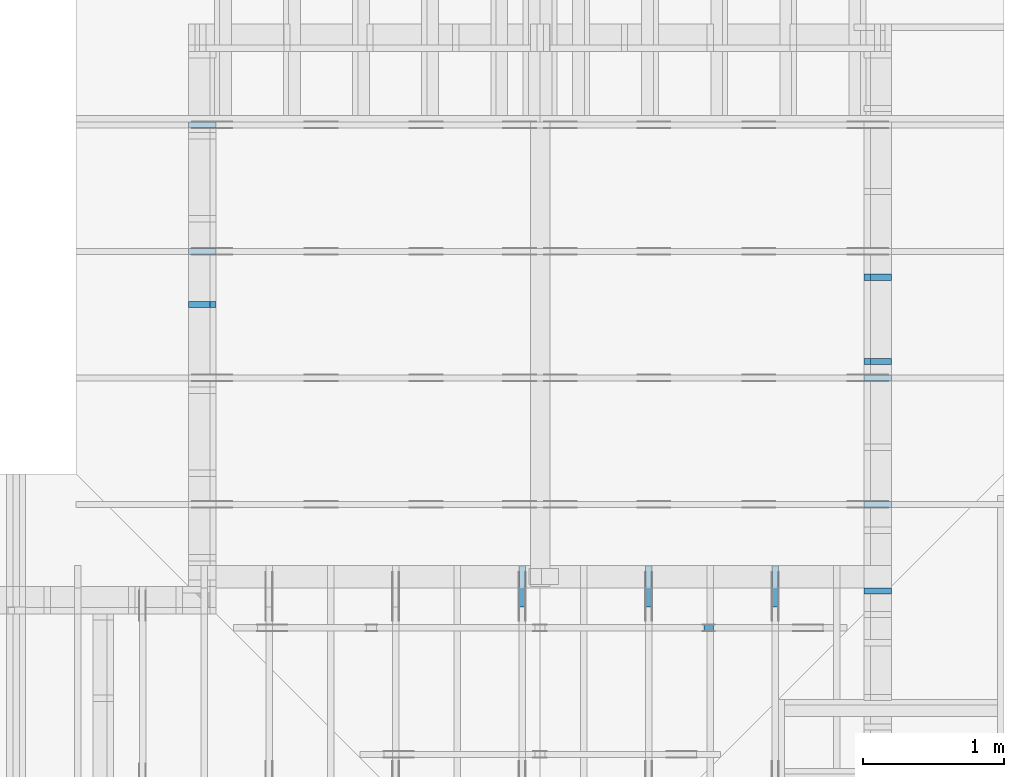
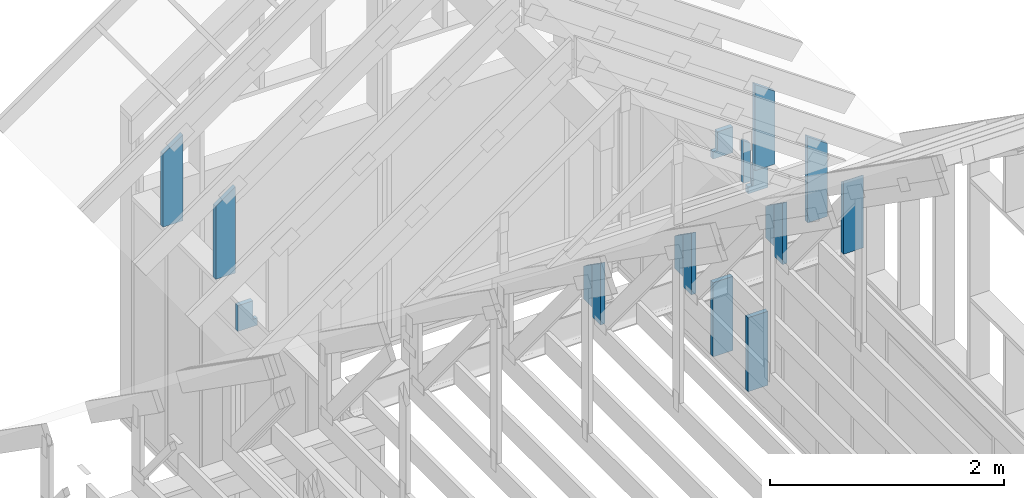
# One storey, part 42 of 70: 17 members, 11 elements without a shape of their own.
"""IFC2X3 building model written with IfcOpenShell, lengths in millimetres."""

from ifc_helpers import new_model, si_unit, frame, origin, origin_with_axes, origin_2d, place, context, project, spatial, faceted_brep, element, aggregate, save


model = new_model("IFC2X3")

# Units and contexts
model_context = context("Model", 3, precision=1e-05, world=origin())
plan_context = context("Plan", 2, precision=1e-05, world=origin_2d())
ifc_project = project(units=[si_unit("LENGTHUNIT", "METRE", prefix="MILLI"), si_unit("AREAUNIT", "SQUARE_METRE"), si_unit("VOLUMEUNIT", "CUBIC_METRE"), si_unit("SOLIDANGLEUNIT", "STERADIAN"), si_unit("PLANEANGLEUNIT", "RADIAN"), si_unit("MASSUNIT", "GRAM"), si_unit("TIMEUNIT", "SECOND"), si_unit("THERMODYNAMICTEMPERATUREUNIT", "DEGREE_CELSIUS"), si_unit("LUMINOUSINTENSITYUNIT", "LUMEN")], contexts=[model_context, plan_context])

# Site, building, storey
site_placement = place(None, origin_with_axes())
site = spatial("IfcSite", under=ifc_project, at=site_placement, CompositionType="ELEMENT")
building_placement = place(site_placement, origin_with_axes())
building = spatial("IfcBuilding", under=site, at=building_placement, Name="Layout 1", CompositionType="ELEMENT")
storey_placement = place(building_placement, origin_with_axes())
storey = spatial("IfcBuildingStorey", under=building, at=storey_placement, Name="Storey 1", CompositionType="ELEMENT", Elevation=0.0)

# Assembly, member
assembly_1_placement = place(storey_placement, frame((7000.0, 11305.0, 1.3776821480501744e-15), z_axis=(1.2246063538223773e-16, 1.0, 6.123031769111886e-17), x_axis=(-1.0, 1.2246063538223773e-16, 0.0)))
assembly_1 = element("IfcElementAssembly", 1, at=assembly_1_placement, inside=storey, Name="T4", AssemblyPlace="FACTORY", PredefinedType="TRUSS")
member_1_placement = place(assembly_1_placement, frame((-195.00000000029104, 898.4894251432052, -45.0), z_axis=(0.0, 0.0, 1.0), x_axis=(-1.960047792473607e-15, -1.0, 0.0)))
member_1 = element("IfcMember", 2, at=member_1_placement, Name="E2", context=model_context, shape_type="Brep", body=[
    faceted_brep([(898.4894251432048, 195.0000000002928, 45.0), (136.54046995116335, 195.0000000002928, 45.0), (0.0, 0.0, 45.0), (898.4894251432048, 0.0, 45.0), (136.54046995116335, 195.0000000002928, 1.67208327056088e-14), (898.4894251432048, 195.0000000002928, 1.1002958588725838e-13), (898.4894251432048, 0.0, 1.1002958588725838e-13), (0.0, 0.0, 0.0), (-1.1640850691049727e-14, 8.15101140505067e-15, 8.701351488741532e-31), (-9.383788395138588e-15, 6.5705993712440116e-15, 45.0), (136.54046995116337, 195.00000000029124, 45.0), (136.54046995116337, 195.00000000029124, -3.074169377230906e-30), (898.4894251432048, 2.9190987951436253e-10, 5.452994756240366e-29), (898.4894251432048, 2.9191263487865863e-10, 45.0), (-8.951892333787164e-28, 2.755364296100349e-15, 45.0), (0.0, 0.0, 0.0), (898.4894251432048, 195.0000000002928, 0.0), (898.4894251432048, 195.0000000002928, 45.0), (898.4894251432048, 2.928004505520221e-10, 45.0), (898.4894251432048, 2.928004505520221e-10, 0.0), (136.54046995116332, 195.0000000002913, 0.0), (136.54046995116332, 195.0000000002913, 45.0), (898.4894251432048, 195.00000000029277, 45.0), (898.4894251432048, 195.00000000029277, 0.0)], [[[0, 1, 2, 3]], [[4, 5, 6, 7]], [[8, 9, 10, 11]], [[12, 13, 14, 15]], [[16, 17, 18, 19]], [[20, 21, 22, 23]]]),
])
aggregate(assembly_1, [member_1])

assembly_2_placement = place(storey_placement, frame((7000.0, 10405.0, 1.3776821480501744e-15), z_axis=(1.2246063538223773e-16, 1.0, 6.123031769111886e-17), x_axis=(-1.0, 1.2246063538223773e-16, 0.0)))
assembly_2 = element("IfcElementAssembly", 3, at=assembly_2_placement, inside=storey, Name="T4", AssemblyPlace="FACTORY", PredefinedType="TRUSS")
member_2_placement = place(assembly_2_placement, frame((-195.00000000029104, 898.4894251432052, -45.0), z_axis=(0.0, 0.0, 1.0), x_axis=(-1.960047792473607e-15, -1.0, 0.0)))
member_2 = element("IfcMember", 4, at=member_2_placement, Name="E2", context=model_context, shape_type="Brep", body=[
    faceted_brep([(898.4894251432048, 195.0000000002928, 45.0), (136.54046995116335, 195.0000000002928, 45.0), (0.0, 0.0, 45.0), (898.4894251432048, 0.0, 45.0), (136.54046995116335, 195.0000000002928, 1.67208327056088e-14), (898.4894251432048, 195.0000000002928, 1.1002958588725838e-13), (898.4894251432048, 0.0, 1.1002958588725838e-13), (0.0, 0.0, 0.0), (-1.1640850691049727e-14, 8.15101140505067e-15, 8.701351488741532e-31), (-9.383788395138588e-15, 6.5705993712440116e-15, 45.0), (136.54046995116337, 195.00000000029124, 45.0), (136.54046995116337, 195.00000000029124, -3.074169377230906e-30), (898.4894251432048, 2.9190987951436253e-10, 5.452994756240366e-29), (898.4894251432048, 2.9191263487865863e-10, 45.0), (-8.951892333787164e-28, 2.755364296100349e-15, 45.0), (0.0, 0.0, 0.0), (898.4894251432048, 195.0000000002928, 0.0), (898.4894251432048, 195.0000000002928, 45.0), (898.4894251432048, 2.928004505520221e-10, 45.0), (898.4894251432048, 2.928004505520221e-10, 0.0), (136.54046995116332, 195.0000000002913, 0.0), (136.54046995116332, 195.0000000002913, 45.0), (898.4894251432048, 195.00000000029277, 45.0), (898.4894251432048, 195.00000000029277, 0.0)], [[[0, 1, 2, 3]], [[4, 5, 6, 7]], [[8, 9, 10, 11]], [[12, 13, 14, 15]], [[16, 17, 18, 19]], [[20, 21, 22, 23]]]),
])
aggregate(assembly_2, [member_2])

assembly_3_placement = place(storey_placement, frame((7000.0, 11805.0, -2470.0), z_axis=(-1.0, 1.836909530733566e-16, 6.123031769111886e-17), x_axis=(-1.836909530733566e-16, -1.0, 0.0)))
assembly_3 = element("IfcElementAssembly", 5, at=assembly_3_placement, inside=storey, Name="VE1", AssemblyPlace="FACTORY", PredefinedType="NOTDEFINED")
member_3_placement = place(assembly_3_placement, frame((1777.5000000036816, 2425.0, -195.00000000000003), z_axis=(0.0, 0.0, 1.0), x_axis=(-1.836909530733566e-16, -1.0, 0.0)))
member_3 = element("IfcMember", 6, at=member_3_placement, Name="S40", context=model_context, shape_type="Brep", body=[
    faceted_brep([(0.0, 45.00000000001455, 45.00000000000003), (195.00000000186265, 45.00000000001455, 45.00000000000005), (195.00000000186265, 0.0, 45.00000000000005), (0.0, 0.0, 45.00000000000003), (195.00000000186265, 45.00000000001455, 2.842170943040401e-14), (195.00000000186265, 45.00000000001455, 45.00000000000003), (195.00000000186265, 1.0459189070388675e-11, 45.00000000000003), (195.00000000186265, 1.0459189070388675e-11, 2.842170943040401e-14), (2.7553642961003504e-15, -3.3742366240998114e-31, 45.00000000000003), (1.1939911949768181e-14, -1.4621692037765844e-30, 195.00000000000006), (1.7450640541970662e-14, 45.00000000001455, 195.00000000000006), (8.26609288830283e-15, 45.00000000001455, 45.00000000000003), (270.0, -4.959655732980628e-14, 2.842170943040401e-14), (270.0, -3.76566453800381e-14, 195.00000000000003), (2.1932538056648764e-30, 1.193991194976818e-14, 195.00000000000003), (5.061354936149717e-31, 2.7553642961003504e-15, 45.00000000000003), (195.00000000186265, -3.306437155354634e-14, 45.00000000000003), (195.00000000186265, -3.5819735849646686e-14, 2.842170943040401e-14), (-1.6871183120499057e-31, 45.00000000001455, 45.00000000000003), (-7.310846018882921e-31, 45.00000000001454, 195.00000000000003), (270.0, 45.00000000001452, 195.00000000000003), (270.0, 45.00000000001454, 2.8421709430404004e-14), (195.00000000186265, 45.00000000001454, 2.8421709430404004e-14), (195.00000000186265, 45.00000000001454, 45.00000000000003), (270.0, 45.00000000001455, 0.0), (270.0, 45.00000000001455, 195.00000000000003), (270.0, 1.4551915228366852e-11, 195.00000000000003), (270.0, 1.4551915228366852e-11, 0.0), (270.0, 45.00000000001455, 195.00000000000003), (0.0, 45.00000000001455, 195.00000000000003), (0.0, 0.0, 195.00000000000003), (270.0, 0.0, 195.00000000000003), (195.00000000186265, 45.00000000001455, 5.2301533330168465e-14), (270.0, 45.00000000001455, 6.148608098360819e-14), (270.0, 1.4551915228366852e-11, 6.148608098360819e-14), (195.00000000186265, 1.4551915228366852e-11, 5.2301533330168465e-14)], [[[0, 1, 2, 3]], [[4, 5, 6, 7]], [[8, 9, 10, 11]], [[12, 13, 14, 15, 16, 17]], [[18, 19, 20, 21, 22, 23]], [[24, 25, 26, 27]], [[28, 29, 30, 31]], [[32, 33, 34, 35]]]),
])
aggregate(assembly_3, [member_3])

# Assembly, members
assembly_4_placement = place(storey_placement, frame((12000.0, 0.0, -2470.0), z_axis=(1.0, -6.123031769111886e-17, 6.123031769111886e-17), x_axis=(6.123031769111886e-17, 1.0, 0.0)))
assembly_4 = element("IfcElementAssembly", 7, at=assembly_4_placement, inside=storey, Name="VE5", AssemblyPlace="FACTORY", PredefinedType="NOTDEFINED")
member_4_placement = place(assembly_4_placement, frame((9577.500000001834, 2425.0, -195.00000000000003), z_axis=(0.0, 0.0, 1.0), x_axis=(-1.836909530733566e-16, -1.0, 0.0)))
member_4 = element("IfcMember", 8, at=member_4_placement, Name="S40", context=model_context, shape_type="Brep", body=[
    faceted_brep([(0.0, 45.0, 45.00000000000003), (195.00000000186265, 45.0, 45.00000000000005), (195.00000000186265, 0.0, 45.00000000000005), (0.0, 0.0, 45.00000000000003), (195.00000000186265, 45.000000000010914, 2.842170943040401e-14), (195.00000000186265, 45.000000000010914, 45.00000000000003), (195.00000000186265, 1.0913936421275139e-11, 45.00000000000003), (195.00000000186265, 1.0913936421275139e-11, 2.842170943040401e-14), (2.7553642961003504e-15, -3.3742366240998114e-31, 45.00000000000003), (1.193991194976818e-14, -1.4621692037765842e-30, 195.00000000000003), (1.7450640541968876e-14, 45.0, 195.00000000000003), (8.266092888301048e-15, 45.0, 45.00000000000003), (270.0, -4.959655732980628e-14, 2.842170943040401e-14), (270.0, -3.76566453800381e-14, 195.00000000000003), (2.1932538056648764e-30, 1.193991194976818e-14, 195.00000000000003), (5.061354936149717e-31, 2.7553642961003504e-15, 45.00000000000003), (195.00000000186265, -3.306437155354634e-14, 45.00000000000003), (195.00000000186265, -3.5819735849646686e-14, 2.842170943040401e-14), (-1.6871183120499057e-31, 45.000000000010914, 45.00000000000003), (-7.310846018882921e-31, 45.0000000000109, 195.00000000000003), (270.0, 45.000000000010886, 195.00000000000003), (270.0, 45.0000000000109, 2.842170943040401e-14), (195.00000000186265, 45.0000000000109, 2.842170943040401e-14), (195.00000000186265, 45.0000000000109, 45.00000000000003), (270.0, 45.00000000001455, 0.0), (270.0, 45.00000000001455, 195.00000000000003), (270.0, 1.4551915228366852e-11, 195.00000000000003), (270.0, 1.4551915228366852e-11, 0.0), (270.0, 45.00000000001455, 195.00000000000003), (0.0, 45.00000000001455, 195.00000000000003), (0.0, 0.0, 195.00000000000003), (270.0, 0.0, 195.00000000000003), (195.00000000186265, 45.000000000010914, 5.2301533330168465e-14), (270.0, 45.000000000010914, 6.148608098360819e-14), (270.0, 1.4551915228366852e-11, 6.148608098360819e-14), (195.00000000186265, 1.4551915228366852e-11, 5.2301533330168465e-14)], [[[0, 1, 2, 3]], [[4, 5, 6, 7]], [[8, 9, 10, 11]], [[12, 13, 14, 15, 16, 17]], [[18, 19, 20, 21, 22, 23]], [[24, 25, 26, 27]], [[28, 29, 30, 31]], [[32, 33, 34, 35]]]),
])
member_5_placement = place(assembly_4_placement, frame((9577.500000001819, 863.171384747213, -195.0), z_axis=(0.0, 0.0, 1.0), x_axis=(-1.836909530733566e-16, -1.0, 0.0)))
member_5 = element("IfcMember", 9, at=member_5_placement, Name="S36", context=model_context, shape_type="Brep", body=[
    faceted_brep([(773.1713847472129, 45.0, 195.0), (0.0, 45.0, 195.0), (1.1368683772161603e-13, 2.9103830456733704e-11, 195.0), (773.1713847472129, 2.9103830456733704e-11, 195.0), (0.0, 45.0, 0.0), (773.1713847472129, 45.0, 9.468305903550827e-14), (773.1713847472129, 2.9103830456733704e-11, 9.468305903550827e-14), (1.1368683772161603e-13, 2.9103830456733704e-11, 1.392216238198645e-29), (1.1368683772161555e-13, 2.9103830456733704e-11, 2.942726775082116e-44), (1.2562674967138373e-13, 2.9103830456733704e-11, 195.0), (1.123339160406752e-14, 45.000000000029104, 195.0), (-7.065203457006586e-16, 45.000000000029104, 4.326046522249051e-32), (773.1713847472129, 1.1981204437069186e-13, -7.336129540039744e-30), (773.1713847472129, 1.3175195632046003e-13, 195.0), (1.1368683772161646e-13, 2.911577036868347e-11, 195.0), (1.1368683772161603e-13, 2.9103830456733704e-11, 0.0), (773.1713847472129, 45.0, 0.0), (773.1713847472129, 45.0, 195.0), (773.1713847472129, 0.0, 195.0), (773.1713847472129, 0.0, 0.0), (0.0, 45.000000000029104, 0.0), (-4.0389678347315804e-28, 45.00000000002909, 195.0), (773.1713847472129, 45.00000000000003, 195.0), (773.1713847472129, 45.00000000000004, 2.7610131682735413e-30)], [[[0, 1, 2, 3]], [[4, 5, 6, 7]], [[8, 9, 10, 11]], [[12, 13, 14, 15]], [[16, 17, 18, 19]], [[20, 21, 22, 23]]]),
])
member_6_placement = place(assembly_4_placement, frame((10177.500000001834, 2425.0, -195.0), z_axis=(0.0, 0.0, 1.0), x_axis=(-1.836909530733566e-16, -1.0, 0.0)))
member_6 = element("IfcMember", 10, at=member_6_placement, Name="S40", context=model_context, shape_type="Brep", body=[
    faceted_brep([(0.0, 45.0, 45.0), (195.00000000186265, 45.0, 45.00000000000002), (195.00000000186265, 0.0, 45.00000000000002), (0.0, 0.0, 45.0), (195.00000000186265, 45.000000000010914, 0.0), (195.00000000186265, 45.000000000010914, 45.0), (195.00000000186265, 0.0, 45.0), (195.00000000186265, 0.0, 0.0), (2.755364296100349e-15, -3.3742366240998092e-31, 45.0), (1.1939911949768178e-14, -1.462169203776584e-30, 195.0), (1.7450640541968876e-14, 45.0, 195.0), (8.266092888301046e-15, 45.0, 45.0), (270.0, -4.959655732980628e-14, 3.0368129616898283e-30), (270.0, -3.76566453800381e-14, 195.0), (2.193253805664876e-30, 1.1939911949768178e-14, 195.0), (5.061354936149714e-31, 2.755364296100349e-15, 45.0), (195.00000000186265, -3.306437155354634e-14, 45.0), (195.00000000186265, -3.5819735849646686e-14, 2.193253805685826e-30), (-1.6871183120499046e-31, 45.000000000010914, 45.0), (-7.31084601888292e-31, 45.0000000000109, 195.0), (270.0, 45.000000000010886, 195.0), (270.0, 45.0000000000109, -1.1832913578315177e-30), (195.00000000186265, 45.0000000000109, -7.888609052210118e-31), (195.00000000186265, 45.0000000000109, 45.0), (270.0, 45.00000000001455, 0.0), (270.0, 45.00000000001455, 195.0), (270.0, 0.0, 195.0), (270.0, 0.0, 0.0), (270.0, 45.00000000001455, 195.0), (0.0, 45.00000000001455, 195.0), (0.0, 0.0, 195.0), (270.0, 0.0, 195.0), (195.00000000186265, 45.000000000010914, 2.3879823899764457e-14), (270.0, 45.000000000010914, 3.3064371553204186e-14), (270.0, 0.0, 3.3064371553204186e-14), (195.00000000186265, 0.0, 2.3879823899764457e-14)], [[[0, 1, 2, 3]], [[4, 5, 6, 7]], [[8, 9, 10, 11]], [[12, 13, 14, 15, 16, 17]], [[18, 19, 20, 21, 22, 23]], [[24, 25, 26, 27]], [[28, 29, 30, 31]], [[32, 33, 34, 35]]]),
])
member_7_placement = place(assembly_4_placement, frame((10177.500000001819, 863.171384747213, -195.0), z_axis=(0.0, 0.0, 1.0), x_axis=(-1.836909530733566e-16, -1.0, 0.0)))
member_7 = element("IfcMember", 11, at=member_7_placement, Name="S36", context=model_context, shape_type="Brep", body=[
    faceted_brep([(773.1713847472129, 45.0, 195.0), (0.0, 45.0, 195.0), (1.1368683772161603e-13, 1.4551915228366852e-11, 195.0), (773.1713847472129, 1.4551915228366852e-11, 195.0), (0.0, 45.0, 0.0), (773.1713847472129, 45.0, 9.468305903550827e-14), (773.1713847472129, 1.4551915228366852e-11, 9.468305903550827e-14), (1.1368683772161603e-13, 1.4551915228366852e-11, 1.392216238198645e-29), (1.1368683772161582e-13, 1.4551915228366852e-11, 1.2611686178923354e-44), (1.25626749671384e-13, 1.4551915228366852e-11, 195.0), (1.123339160403079e-14, 45.000000000029104, 195.0), (-7.06520345737388e-16, 45.000000000029104, 4.3260465224739594e-32), (773.1713847472129, -1.1106272091285424e-14, 6.800405685133444e-31), (773.1713847472129, 8.336398584827545e-16, 195.0), (1.1368683772161626e-13, 1.456385514031662e-11, 195.0), (1.1368683772161603e-13, 1.4551915228366852e-11, 0.0), (773.1713847472129, 45.0, 0.0), (773.1713847472129, 45.0, 195.0), (773.1713847472129, 0.0, 195.0), (773.1713847472129, 0.0, 0.0), (0.0, 45.000000000029104, 0.0), (-4.0389678347315804e-28, 45.00000000002909, 195.0), (773.1713847472129, 45.00000000000003, 195.0), (773.1713847472129, 45.00000000000004, 2.7610131682735413e-30)], [[[0, 1, 2, 3]], [[4, 5, 6, 7]], [[8, 9, 10, 11]], [[12, 13, 14, 15]], [[16, 17, 18, 19]], [[20, 21, 22, 23]]]),
])
aggregate(assembly_4, [member_4, member_5, member_6, member_7])

assembly_5_placement = place(storey_placement, frame((10250.0, 8000.0, -9.081170196248781e-13), z_axis=(-1.0, 1.836909530733566e-16, 6.123031769111886e-17), x_axis=(-1.836909530733566e-16, -1.0, 0.0)))
assembly_5 = element("IfcElementAssembly", 12, at=assembly_5_placement, inside=storey, Name="T3", AssemblyPlace="FACTORY", PredefinedType="TRUSS")
member_8_placement = place(assembly_5_placement, frame((145.0000000001018, 220.00000000000097, -45.0), z_axis=(0.0, 0.0, 1.0), x_axis=(6.123031769111886e-17, 1.0, 0.0)))
member_8 = element("IfcMember", 13, at=member_8_placement, Name="E3", context=model_context, shape_type="Brep", body=[
    faceted_brep([(541.9489551912693, 145.00000000010186, 45.0), (0.0, 145.00000000010186, 45.0), (0.0, 1.964451712410664e-09, 45.0), (643.4790482318776, 1.964451712410664e-09, 45.0), (0.0, 145.00000000010186, 0.0), (541.9489551912693, 145.00000000010186, 6.636741339746272e-14), (643.4790482318776, 1.964451712410664e-09, 7.880085310163334e-14), (0.0, 1.964451712410664e-09, 0.0), (2.4056800487953487e-25, 1.964451712410664e-09, -1.4730055365092553e-41), (2.7553642963409167e-15, 1.964451712410664e-09, 45.0), (2.0512156426537286e-14, 145.0000000001018, 45.0), (1.7756792130436937e-14, 145.0000000001018, -1.087254023321813e-30), (643.4790482318776, 4.8214030877080846e-15, -2.952160427766236e-31), (643.4790482318776, 7.576767383808433e-15, 45.0), (8.411721935180507e-27, 1.9644544677749603e-09, 45.0), (0.0, 1.964451712410664e-09, 0.0), (541.9489551912693, 145.00000000010183, -6.310887241768095e-30), (541.9489551912693, 145.00000000010183, 45.0), (643.4790482318776, 0.0, 45.0), (643.4790482318776, 0.0, -6.310887241768095e-30), (0.0, 145.0000000001018, 0.0), (0.0, 145.0000000001018, 45.0), (541.9489551912693, 145.0000000001019, 45.0), (541.9489551912693, 145.0000000001019, 1.5777218104420236e-30)], [[[0, 1, 2, 3]], [[4, 5, 6, 7]], [[8, 9, 10, 11]], [[12, 13, 14, 15]], [[16, 17, 18, 19]], [[20, 21, 22, 23]]]),
])
member_9_placement = place(assembly_5_placement, frame((0.0, 322.49999999813735, -45.0), z_axis=(0.0, 0.0, 1.0), x_axis=(6.123031769111886e-17, 1.0, 0.0)))
member_9 = element("IfcMember", 14, at=member_9_placement, Name="E4", context=model_context, shape_type="Brep", body=[
    faceted_brep([(337.91886215284467, 145.0, 45.0), (0.0, 145.0, 45.0), (0.0, 0.0, 45.0), (439.44895519316196, 0.0, 45.0), (0.0, 145.0, 0.0), (337.91886215284467, 145.0, 4.138175856688016e-14), (439.44895519316196, 0.0, 5.381519827101513e-14), (0.0, 0.0, 0.0), (0.0, 0.0, 0.0), (2.755364296100349e-15, -3.3742366240998092e-31, 45.0), (2.051215642652482e-14, 145.0, 45.0), (1.775679213042447e-14, 145.0, -1.0872540233210496e-30), (439.44895519316196, -8.07227974065227e-14, 6.590243373489615e-30), (439.44895519316196, -7.796743311042235e-14, 45.0), (5.061354936149714e-31, 2.755364296100349e-15, 45.0), (0.0, 0.0, 0.0), (337.91886215284467, 144.99999999999997, 0.0), (337.91886215284467, 144.99999999999997, 45.0), (439.44895519316196, 0.0, 45.0), (439.44895519316196, 0.0, 0.0), (0.0, 145.0, 0.0), (-1.6871183120499046e-31, 145.0, 45.0), (337.91886215284467, 144.99999999999997, 45.0), (337.91886215284467, 144.99999999999997, -1.5777218104420236e-30)], [[[0, 1, 2, 3]], [[4, 5, 6, 7]], [[8, 9, 10, 11]], [[12, 13, 14, 15]], [[16, 17, 18, 19]], [[20, 21, 22, 23]]]),
])
aggregate(assembly_5, [member_8, member_9])

assembly_6_placement = place(storey_placement, frame((9350.0, 8000.0, -9.081170196248781e-13), z_axis=(-1.0, 1.836909530733566e-16, 6.123031769111886e-17), x_axis=(-1.836909530733566e-16, -1.0, 0.0)))
assembly_6 = element("IfcElementAssembly", 15, at=assembly_6_placement, inside=storey, Name="T3", AssemblyPlace="FACTORY", PredefinedType="TRUSS")
member_10_placement = place(assembly_6_placement, frame((145.0000000001018, 220.00000000000097, -45.0), z_axis=(0.0, 0.0, 1.0), x_axis=(6.123031769111886e-17, 1.0, 0.0)))
member_10 = element("IfcMember", 16, at=member_10_placement, Name="E3", context=model_context, shape_type="Brep", body=[
    faceted_brep([(541.9489551912693, 145.00000000010186, 45.0), (0.0, 145.00000000010186, 45.0), (0.0, 1.964451712410664e-09, 45.0), (643.4790482318776, 1.964451712410664e-09, 45.0), (0.0, 145.00000000010186, 0.0), (541.9489551912693, 145.00000000010186, 6.636741339746272e-14), (643.4790482318776, 1.964451712410664e-09, 7.880085310163334e-14), (0.0, 1.964451712410664e-09, 0.0), (2.4056800487953487e-25, 1.964451712410664e-09, -1.4730055365092553e-41), (2.7553642963409167e-15, 1.964451712410664e-09, 45.0), (2.0512156426537286e-14, 145.0000000001018, 45.0), (1.7756792130436937e-14, 145.0000000001018, -1.087254023321813e-30), (643.4790482318776, 4.8214030877080846e-15, -2.952160427766236e-31), (643.4790482318776, 7.576767383808433e-15, 45.0), (8.411721935180507e-27, 1.9644544677749603e-09, 45.0), (0.0, 1.964451712410664e-09, 0.0), (541.9489551912693, 145.00000000010183, -6.310887241768095e-30), (541.9489551912693, 145.00000000010183, 45.0), (643.4790482318776, 0.0, 45.0), (643.4790482318776, 0.0, -6.310887241768095e-30), (0.0, 145.0000000001018, 0.0), (0.0, 145.0000000001018, 45.0), (541.9489551912693, 145.0000000001019, 45.0), (541.9489551912693, 145.0000000001019, 1.5777218104420236e-30)], [[[0, 1, 2, 3]], [[4, 5, 6, 7]], [[8, 9, 10, 11]], [[12, 13, 14, 15]], [[16, 17, 18, 19]], [[20, 21, 22, 23]]]),
])
member_11_placement = place(assembly_6_placement, frame((0.0, 322.49999999813735, -45.0), z_axis=(0.0, 0.0, 1.0), x_axis=(6.123031769111886e-17, 1.0, 0.0)))
member_11 = element("IfcMember", 17, at=member_11_placement, Name="E4", context=model_context, shape_type="Brep", body=[
    faceted_brep([(337.91886215284467, 145.0, 45.0), (0.0, 145.0, 45.0), (0.0, 0.0, 45.0), (439.44895519316196, 0.0, 45.0), (0.0, 145.0, 0.0), (337.91886215284467, 145.0, 4.138175856688016e-14), (439.44895519316196, 0.0, 5.381519827101513e-14), (0.0, 0.0, 0.0), (0.0, 0.0, 0.0), (2.755364296100349e-15, -3.3742366240998092e-31, 45.0), (2.051215642652482e-14, 145.0, 45.0), (1.775679213042447e-14, 145.0, -1.0872540233210496e-30), (439.44895519316196, -8.07227974065227e-14, 6.590243373489615e-30), (439.44895519316196, -7.796743311042235e-14, 45.0), (5.061354936149714e-31, 2.755364296100349e-15, 45.0), (0.0, 0.0, 0.0), (337.91886215284467, 144.99999999999997, 0.0), (337.91886215284467, 144.99999999999997, 45.0), (439.44895519316196, 0.0, 45.0), (439.44895519316196, 0.0, 0.0), (0.0, 145.0, 0.0), (-1.6871183120499046e-31, 145.0, 45.0), (337.91886215284467, 144.99999999999997, 45.0), (337.91886215284467, 144.99999999999997, -1.5777218104420236e-30)], [[[0, 1, 2, 3]], [[4, 5, 6, 7]], [[8, 9, 10, 11]], [[12, 13, 14, 15]], [[16, 17, 18, 19]], [[20, 21, 22, 23]]]),
])
aggregate(assembly_6, [member_10, member_11])

assembly_7_placement = place(storey_placement, frame((11150.0, 8000.0, -9.081170196248781e-13), z_axis=(-1.0, 1.836909530733566e-16, 6.123031769111886e-17), x_axis=(-1.836909530733566e-16, -1.0, 0.0)))
assembly_7 = element("IfcElementAssembly", 18, at=assembly_7_placement, inside=storey, Name="T3", AssemblyPlace="FACTORY", PredefinedType="TRUSS")
member_12_placement = place(assembly_7_placement, frame((145.0000000001018, 220.00000000000097, -45.0), z_axis=(0.0, 0.0, 1.0), x_axis=(6.123031769111886e-17, 1.0, 0.0)))
member_12 = element("IfcMember", 19, at=member_12_placement, Name="E3", context=model_context, shape_type="Brep", body=[
    faceted_brep([(541.9489551912693, 145.00000000010186, 45.0), (0.0, 145.00000000010186, 45.0), (0.0, 1.964451712410664e-09, 45.0), (643.4790482318776, 1.964451712410664e-09, 45.0), (0.0, 145.00000000010186, 0.0), (541.9489551912693, 145.00000000010186, 6.636741339746272e-14), (643.4790482318776, 1.964451712410664e-09, 7.880085310163334e-14), (0.0, 1.964451712410664e-09, 0.0), (2.4056800487953487e-25, 1.964451712410664e-09, -1.4730055365092553e-41), (2.7553642963409167e-15, 1.964451712410664e-09, 45.0), (2.0512156426537286e-14, 145.0000000001018, 45.0), (1.7756792130436937e-14, 145.0000000001018, -1.087254023321813e-30), (643.4790482318776, 4.8214030877080846e-15, -2.952160427766236e-31), (643.4790482318776, 7.576767383808433e-15, 45.0), (8.411721935180507e-27, 1.9644544677749603e-09, 45.0), (0.0, 1.964451712410664e-09, 0.0), (541.9489551912693, 145.00000000010183, -6.310887241768095e-30), (541.9489551912693, 145.00000000010183, 45.0), (643.4790482318776, 0.0, 45.0), (643.4790482318776, 0.0, -6.310887241768095e-30), (0.0, 145.0000000001018, 0.0), (0.0, 145.0000000001018, 45.0), (541.9489551912693, 145.0000000001019, 45.0), (541.9489551912693, 145.0000000001019, 1.5777218104420236e-30)], [[[0, 1, 2, 3]], [[4, 5, 6, 7]], [[8, 9, 10, 11]], [[12, 13, 14, 15]], [[16, 17, 18, 19]], [[20, 21, 22, 23]]]),
])
member_13_placement = place(assembly_7_placement, frame((0.0, 322.49999999813735, -45.0), z_axis=(0.0, 0.0, 1.0), x_axis=(6.123031769111886e-17, 1.0, 0.0)))
member_13 = element("IfcMember", 20, at=member_13_placement, Name="E4", context=model_context, shape_type="Brep", body=[
    faceted_brep([(337.91886215284467, 145.0, 45.0), (0.0, 145.0, 45.0), (0.0, 0.0, 45.0), (439.44895519316196, 0.0, 45.0), (0.0, 145.0, 0.0), (337.91886215284467, 145.0, 4.138175856688016e-14), (439.44895519316196, 0.0, 5.381519827101513e-14), (0.0, 0.0, 0.0), (0.0, 0.0, 0.0), (2.755364296100349e-15, -3.3742366240998092e-31, 45.0), (2.051215642652482e-14, 145.0, 45.0), (1.775679213042447e-14, 145.0, -1.0872540233210496e-30), (439.44895519316196, -8.07227974065227e-14, 6.590243373489615e-30), (439.44895519316196, -7.796743311042235e-14, 45.0), (5.061354936149714e-31, 2.755364296100349e-15, 45.0), (0.0, 0.0, 0.0), (337.91886215284467, 144.99999999999997, 0.0), (337.91886215284467, 144.99999999999997, 45.0), (439.44895519316196, 0.0, 45.0), (439.44895519316196, 0.0, 0.0), (0.0, 145.0, 0.0), (-1.6871183120499046e-31, 145.0, 45.0), (337.91886215284467, 144.99999999999997, 45.0), (337.91886215284467, 144.99999999999997, -1.5777218104420236e-30)], [[[0, 1, 2, 3]], [[4, 5, 6, 7]], [[8, 9, 10, 11]], [[12, 13, 14, 15]], [[16, 17, 18, 19]], [[20, 21, 22, 23]]]),
])
aggregate(assembly_7, [member_12, member_13])

# Assembly, member
assembly_8_placement = place(storey_placement, frame((12000.0, 8605.0, 1.3776821480501744e-15), z_axis=(1.2246063538223773e-16, 1.0, 6.123031769111886e-17), x_axis=(-1.0, 1.2246063538223773e-16, 0.0)))
assembly_8 = element("IfcElementAssembly", 21, at=assembly_8_placement, inside=storey, Name="T10", AssemblyPlace="FACTORY", PredefinedType="TRUSS")
member_14_placement = place(assembly_8_placement, frame((195.0, -1.1939911949768178e-14, -45.0), z_axis=(0.0, 0.0, 1.0), x_axis=(6.123031769111886e-17, 1.0, 0.0)))
member_14 = element("IfcMember", 22, at=member_14_placement, Name="E2", context=model_context, shape_type="Brep", body=[
    faceted_brep([(761.9489551902298, 195.0000000000146, 45.0), (0.0, 195.0000000000146, 45.0), (1.1939911949768178e-14, 0.0, 45.0), (898.489425140906, 0.0, 45.0), (0.0, 195.0000000000146, 0.0), (761.9489551902298, 195.0000000000146, 9.330875318142772e-14), (898.489425140906, 0.0, 1.1002958588697687e-13), (1.1939911949768178e-14, 0.0, 1.462169203776584e-30), (1.1939911949768178e-14, 0.0, 0.0), (1.4695276245868527e-14, -3.3742366240998092e-31, 45.0), (3.8575100145404884e-14, 195.0, 45.0), (3.5819735849304535e-14, 195.0, -2.193253805664876e-30), (898.489425140906, 6.111174466091852e-10, 7.337620909297005e-30), (898.489425140906, 6.111202019734813e-10, 45.0), (1.1939911949766304e-14, 2.7553642961003473e-15, 45.0), (1.1939911949768178e-14, -1.5924907264090874e-30, 9.750871309819471e-47), (761.94895519023, 195.0000000000148, 1.8932661725304283e-29), (761.94895519023, 195.0000000000148, 45.0), (898.4894251409063, 6.11407813266851e-10, 45.0), (898.4894251409063, 6.11407813266851e-10, 1.8932661725304283e-29), (0.0, 195.0, 0.0), (0.0, 195.0, 45.0), (761.9489551902298, 195.00000000001467, 45.0), (761.9489551902298, 195.00000000001467, 3.1554436208840472e-30)], [[[0, 1, 2, 3]], [[4, 5, 6, 7]], [[8, 9, 10, 11]], [[12, 13, 14, 15]], [[16, 17, 18, 19]], [[20, 21, 22, 23]]]),
])
aggregate(assembly_8, [member_14])

assembly_9_placement = place(storey_placement, frame((12000.0, 9505.0, 1.3776821480501744e-15), z_axis=(1.2246063538223773e-16, 1.0, 6.123031769111886e-17), x_axis=(-1.0, 1.2246063538223773e-16, 0.0)))
assembly_9 = element("IfcElementAssembly", 23, at=assembly_9_placement, inside=storey, Name="T10", AssemblyPlace="FACTORY", PredefinedType="TRUSS")
member_15_placement = place(assembly_9_placement, frame((195.0, -1.1939911949768178e-14, -45.0), z_axis=(0.0, 0.0, 1.0), x_axis=(6.123031769111886e-17, 1.0, 0.0)))
member_15 = element("IfcMember", 24, at=member_15_placement, Name="E2", context=model_context, shape_type="Brep", body=[
    faceted_brep([(761.9489551902298, 195.0000000000146, 45.0), (0.0, 195.0000000000146, 45.0), (1.1939911949768178e-14, 0.0, 45.0), (898.489425140906, 0.0, 45.0), (0.0, 195.0000000000146, 0.0), (761.9489551902298, 195.0000000000146, 9.330875318142772e-14), (898.489425140906, 0.0, 1.1002958588697687e-13), (1.1939911949768178e-14, 0.0, 1.462169203776584e-30), (1.1939911949768178e-14, 0.0, 0.0), (1.4695276245868527e-14, -3.3742366240998092e-31, 45.0), (3.8575100145404884e-14, 195.0, 45.0), (3.5819735849304535e-14, 195.0, -2.193253805664876e-30), (898.489425140906, 6.111174466091852e-10, 7.337620909297005e-30), (898.489425140906, 6.111202019734813e-10, 45.0), (1.1939911949766304e-14, 2.7553642961003473e-15, 45.0), (1.1939911949768178e-14, -1.5924907264090874e-30, 9.750871309819471e-47), (761.94895519023, 195.0000000000148, 1.8932661725304283e-29), (761.94895519023, 195.0000000000148, 45.0), (898.4894251409063, 6.11407813266851e-10, 45.0), (898.4894251409063, 6.11407813266851e-10, 1.8932661725304283e-29), (0.0, 195.0, 0.0), (0.0, 195.0, 45.0), (761.9489551902298, 195.00000000001467, 45.0), (761.9489551902298, 195.00000000001467, 3.1554436208840472e-30)], [[[0, 1, 2, 3]], [[4, 5, 6, 7]], [[8, 9, 10, 11]], [[12, 13, 14, 15]], [[16, 17, 18, 19]], [[20, 21, 22, 23]]]),
])
aggregate(assembly_9, [member_15])

assembly_10_placement = place(storey_placement, frame((7294.999999999998, 7682.5, 1206.561223771864), z_axis=(0.0, -1.0, 6.123031769111886e-17), x_axis=(1.0, 0.0, 0.0)))
assembly_10 = element("IfcElementAssembly", 25, at=assembly_10_placement, inside=storey, Name="SB1", AssemblyPlace="FACTORY", PredefinedType="TRUSS")
member_16_placement = place(assembly_10_placement, frame((3440.0, 135.754669608728, -45.0), z_axis=(0.0, 0.0, 1.0), x_axis=(6.123031769111886e-17, 1.0, 0.0)))
member_16 = element("IfcMember", 26, at=member_16_placement, Name="W11", context=model_context, shape_type="Brep", body=[
    faceted_brep([(445.9682194778815, 70.0, 45.0), (1.6200374375330284e-11, 70.0, 45.0), (0.0, 0.0, 45.0), (396.9536918031717, 0.0, 45.0), (1.6200374375330284e-11, 70.0, 1.9839081394330692e-27), (445.9682194778815, 70.0, 5.4613551517546616e-14), (396.9536918031717, 0.0, 4.8611201315541376e-14), (0.0, 0.0, 0.0), (0.0, 0.0, 0.0), (2.755364296100349e-15, -6.366237512766345e-28, 45.0), (1.6176174847315136e-11, 70.0, 45.0), (1.6173419483019036e-11, 70.0, 1.6504566195476348e-30), (396.9536918031717, -7.291680197331207e-14, 4.464718949846301e-30), (396.9536918031717, -7.016143767721172e-14, 45.0), (5.061354936149714e-31, 2.755364296100349e-15, 45.0), (0.0, 0.0, 0.0), (445.96821947788163, 69.99999999999997, 6.310887241768095e-30), (445.96821947788163, 69.99999999999997, 45.0), (396.9536918031718, 0.0, 45.0), (396.9536918031718, 0.0, 6.310887241768095e-30), (1.6200374375330284e-11, 70.0, 0.0), (1.6200374375330284e-11, 70.0, 45.0), (445.9682194778815, 69.99999999999997, 45.0), (445.9682194778815, 69.99999999999997, -1.5777218104420236e-30)], [[[0, 1, 2, 3]], [[4, 5, 6, 7]], [[8, 9, 10, 11]], [[12, 13, 14, 15]], [[16, 17, 18, 19]], [[20, 21, 22, 23]]]),
])
aggregate(assembly_10, [member_16])

assembly_11_placement = place(storey_placement, frame((11805.0, 8000.000000000002, 1.1939911949768178e-14), z_axis=(-1.0, 1.836909530733566e-16, 6.123031769111886e-17), x_axis=(-1.836909530733566e-16, -1.0, 0.0)))
assembly_11 = element("IfcElementAssembly", 27, at=assembly_11_placement, inside=storey, Name="VE9", AssemblyPlace="FACTORY", PredefinedType="NOTDEFINED")
member_17_placement = place(assembly_11_placement, frame((54.999999999345164, 44.999999999977895, -195.0), z_axis=(0.0, 0.0, 1.0), x_axis=(4.912238964118604e-13, 1.0, 0.0)))
member_17 = element("IfcMember", 28, at=member_17_placement, Name="S37", context=model_context, shape_type="Brep", body=[
    faceted_brep([(730.0549035176809, 45.00000000014034, 195.0), (0.0, 45.00000000014034, 195.0), (2.2104984509496717e-11, 0.0, 195.0), (761.564242737128, 0.0, 195.0), (0.0, 45.00000000014034, 0.0), (730.0549035176809, 45.00000000014034, 8.940298734869347e-14), (761.564242737128, 0.0, 9.326164104998142e-14), (2.2104984509496717e-11, 0.0, 2.7069904481474905e-27), (2.2104984509496717e-11, 0.0, 0.0), (2.2116924421446485e-11, 5.8629768169739925e-27, 195.0), (2.011517589396228e-14, 44.999999999810825, 195.0), (8.175263944194102e-15, 44.999999999810825, -5.005740085117663e-31), (761.564242737128, 1.5543324042972902e-10, 2.3805216132720207e-29), (761.564242737128, 1.554451803416788e-10, 195.0), (2.2104984509496714e-11, 1.1939911949756893e-14, 195.0), (2.2104984509496717e-11, -1.1284680988552176e-26, 6.90964601971991e-43), (730.0549035176809, 45.00000000014029, 0.0), (730.0549035176809, 45.00000000014029, 195.0), (761.5642427371279, 1.5586465451633558e-10, 195.0), (761.5642427371279, 1.5586465451633558e-10, 0.0), (0.0, 44.999999999810825, 0.0), (6.462348535570529e-27, 44.99999999981081, 195.0), (730.0549035176809, 45.000000000140325, 195.0), (730.0549035176809, 45.00000000014034, 0.0)], [[[0, 1, 2, 3]], [[4, 5, 6, 7]], [[8, 9, 10, 11]], [[12, 13, 14, 15]], [[16, 17, 18, 19]], [[20, 21, 22, 23]]]),
])
aggregate(assembly_11, [member_17])

save(model, "model.ifc")
